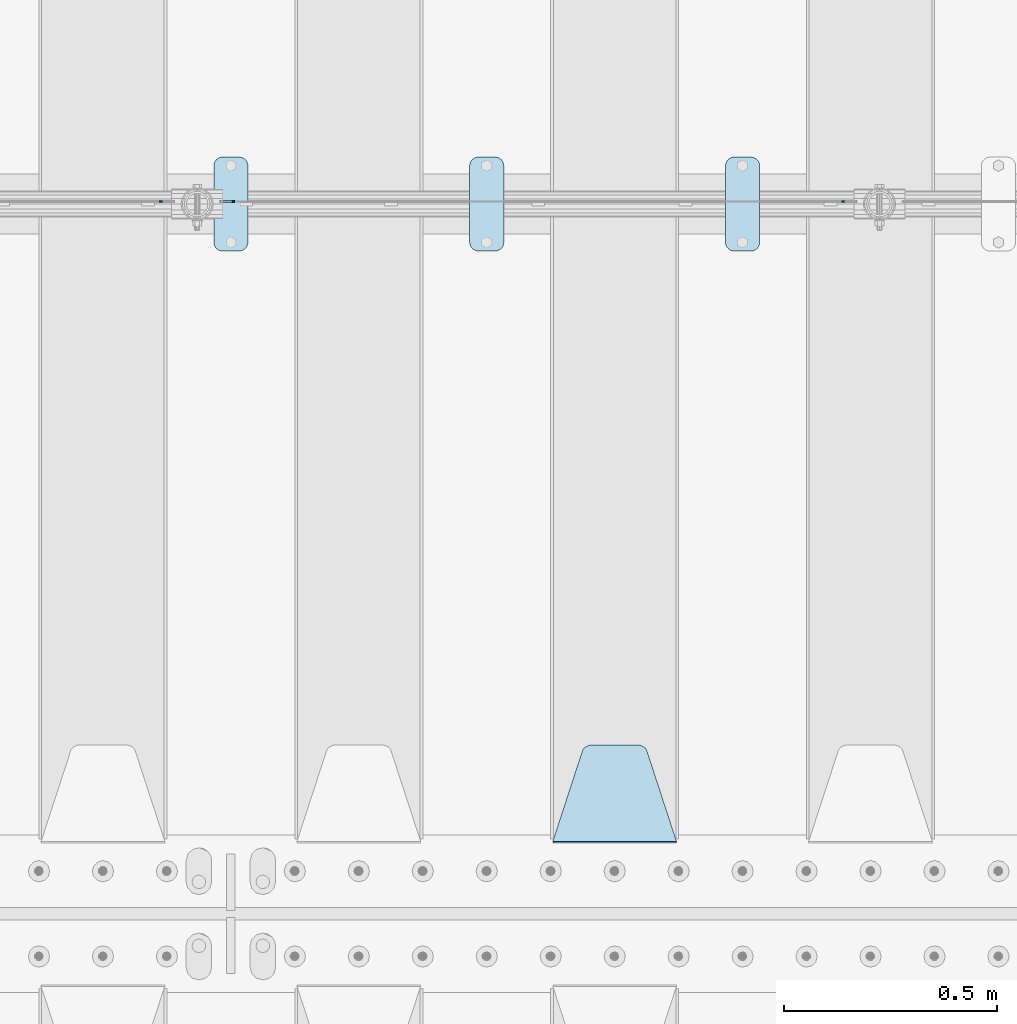
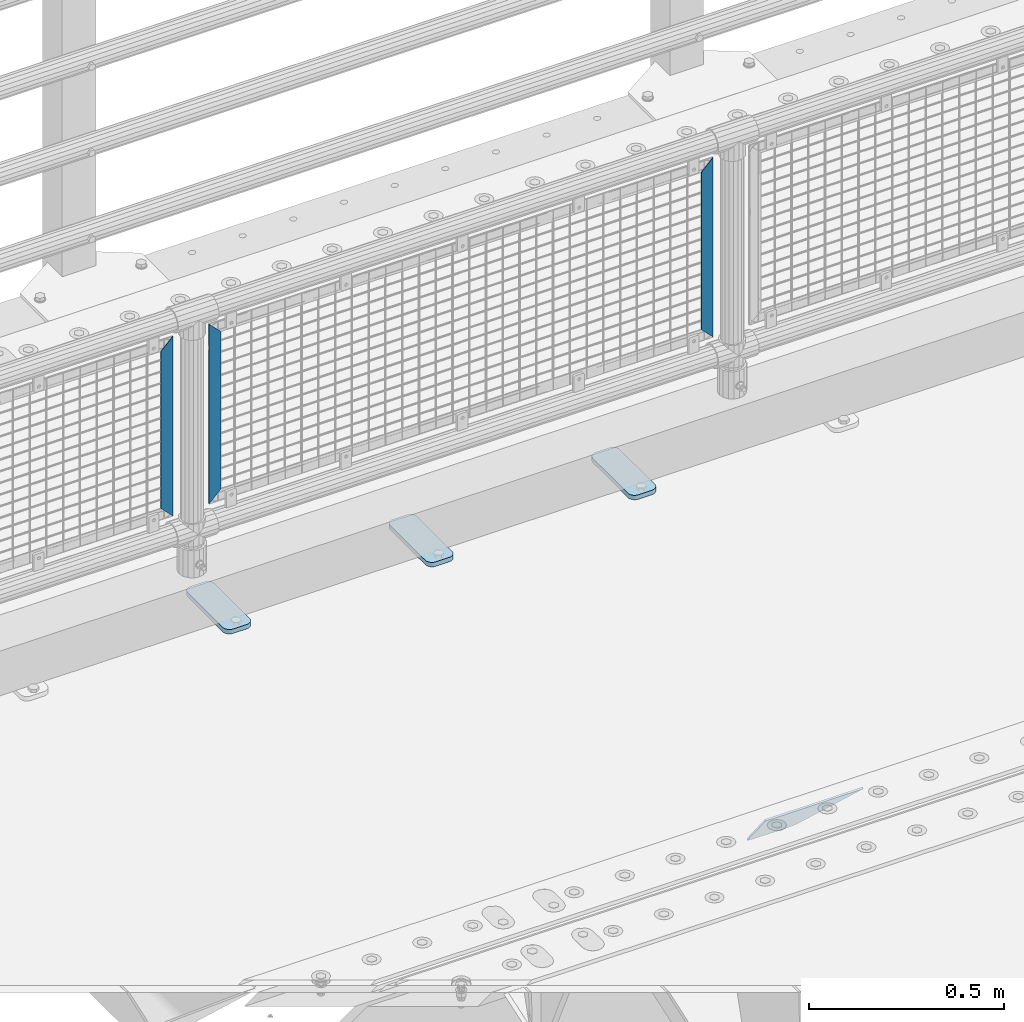
# One storey, part 221 of 257: 7 plates.
"""IFC2X3 building model written with IfcOpenShell, lengths in millimetres."""

from ifc_helpers import new_model, si_unit, frame, origin_with_axes, place, context, subcontext, project, spatial, faceted_brep, material, type_object, element, save


model = new_model("IFC2X3")

# Units and contexts
model_context = context("Model", 3, precision=1e-05, world=origin_with_axes())
body_context = subcontext(model_context, "Body", "Model", "MODEL_VIEW")
ifc_project = project(units=[si_unit("LENGTHUNIT", "METRE", prefix="MILLI"), si_unit("AREAUNIT", "SQUARE_METRE"), si_unit("VOLUMEUNIT", "CUBIC_METRE"), si_unit("MASSUNIT", "GRAM", prefix="KILO"), si_unit("TIMEUNIT", "SECOND"), si_unit("PLANEANGLEUNIT", "RADIAN"), si_unit("SOLIDANGLEUNIT", "STERADIAN"), si_unit("THERMODYNAMICTEMPERATUREUNIT", "DEGREE_CELSIUS"), si_unit("LUMINOUSINTENSITYUNIT", "LUMEN")], contexts=[model_context])

# Site, building, storey
site_placement = place(None, origin_with_axes())
site = spatial("IfcSite", under=ifc_project, at=site_placement, CompositionType="ELEMENT")
building_placement = place(site_placement, origin_with_axes())
building = spatial("IfcBuilding", under=site, at=building_placement, Name="Standard", CompositionType="ELEMENT")
storey_placement = place(building_placement, origin_with_axes())
storey = spatial("IfcBuildingStorey", under=building, at=storey_placement, Name="Undefined", CompositionType="ELEMENT", Elevation=0.0)

# Plates
ifc_material_1 = material(Name="STEEL/S355J2")
plate_type_1 = type_object("IfcPlateType", PredefinedType="NOTDEFINED")
plate_1_placement = place(storey_placement, frame((49110.0, 10774.5, 21.0199999999977), z_axis=(1.0, 0.0, 0.0), x_axis=(0.0, -1.0, 0.0)))
element("IfcPlate", 1, at=plate_1_placement, inside=storey, type_object=plate_type_1, material=ifc_material_1, context=body_context, shape_type="Brep", body=[
    faceted_brep([(0.0, -7.0, 20.0), (0.0, -7.0, 60.0), (0.0, 7.0, 60.0), (0.0, 7.0, 20.0), (0.384294391935327, -7.0, 63.9018064403208), (0.384294391935327, 7.0, 63.9018064403208), (1.52240934977453, -7.0, 67.6536686473046), (1.52240934977453, 7.0, 67.6536686473046), (3.37060775394821, -7.0, 71.1114046603907), (3.37060775394821, 7.0, 71.1114046603907), (5.85786437626848, -7.0, 74.1421356237333), (5.85786437626848, 7.0, 74.1421356237333), (8.88859533960749, -7.0, 76.6293922460536), (8.88859533960749, 7.0, 76.6293922460536), (12.3463313526991, -7.0, 78.4775906502255), (12.3463313526991, 7.0, 78.4775906502255), (16.0981935596774, -7.0, 79.6157056080629), (16.0981935596774, 7.0, 79.6157056080629), (20.0, -7.0, 80.0), (20.0, 7.0, 80.0), (200.0, -7.0, 80.0), (200.0, 7.0, 80.0), (203.901806440323, -7.0, 79.6157056080629), (203.901806440323, 7.0, 79.6157056080629), (207.653668647301, -7.0, 78.4775906502255), (207.653668647301, 7.0, 78.4775906502255), (211.111404660393, -7.0, 76.6293922460536), (211.111404660393, 7.0, 76.6293922460536), (214.142135623732, -7.0, 74.1421356237333), (214.142135623732, 7.0, 74.1421356237333), (216.629392246052, -7.0, 71.1114046603907), (216.629392246052, 7.0, 71.1114046603907), (218.477590650225, -7.0, 67.6536686473046), (218.477590650225, 7.0, 67.6536686473046), (219.615705608065, -7.0, 63.9018064403208), (219.615705608065, 7.0, 63.9018064403208), (220.0, -7.0, 60.0), (220.0, 7.0, 60.0), (220.0, -7.0, 20.0), (220.0, 7.0, 20.0), (219.615705608065, -7.0, 16.0981935596792), (219.615705608065, 7.0, 16.0981935596792), (218.477590650225, -7.0, 12.3463313526954), (218.477590650225, 7.0, 12.3463313526954), (216.629392246052, -7.0, 8.88859533960931), (216.629392246052, 7.0, 8.88859533960931), (214.142135623732, -7.0, 5.85786437626666), (214.142135623732, 7.0, 5.85786437626666), (211.111404660393, -7.0, 3.37060775394639), (211.111404660393, 7.0, 3.37060775394639), (207.653668647301, -7.0, 1.52240934977453), (207.653668647301, 7.0, 1.52240934977453), (203.901806440323, -7.0, 0.384294391937146), (203.901806440323, 7.0, 0.384294391937146), (200.0, -7.0, 0.0), (200.0, 7.0, 0.0), (20.0, -7.0, 0.0), (20.0, 7.0, 0.0), (16.0981935596774, -7.0, 0.384294391937146), (16.0981935596774, 7.0, 0.384294391937146), (12.3463313526991, -7.0, 1.52240934977453), (12.3463313526991, 7.0, 1.52240934977453), (8.88859533960749, -7.0, 3.37060775394639), (8.88859533960749, 7.0, 3.37060775394639), (5.85786437626848, -7.0, 5.85786437626666), (5.85786437626848, 7.0, 5.85786437626666), (3.37060775394821, -7.0, 8.88859533960931), (3.37060775394821, 7.0, 8.88859533960931), (1.52240934977453, -7.0, 12.3463313526954), (1.52240934977453, 7.0, 12.3463313526954), (0.384294391935327, -7.0, 16.0981935596792), (0.384294391935327, 7.0, 16.0981935596792)], [[[0, 1, 2, 3]], [[1, 4, 5, 2]], [[4, 6, 7, 5]], [[6, 8, 9, 7]], [[8, 10, 11, 9]], [[10, 12, 13, 11]], [[12, 14, 15, 13]], [[14, 16, 17, 15]], [[16, 18, 19, 17]], [[18, 20, 21, 19]], [[20, 22, 23, 21]], [[22, 24, 25, 23]], [[24, 26, 27, 25]], [[26, 28, 29, 27]], [[28, 30, 31, 29]], [[30, 32, 33, 31]], [[32, 34, 35, 33]], [[34, 36, 37, 35]], [[36, 38, 39, 37]], [[38, 40, 41, 39]], [[40, 42, 43, 41]], [[42, 44, 45, 43]], [[44, 46, 47, 45]], [[46, 48, 49, 47]], [[48, 50, 51, 49]], [[50, 52, 53, 51]], [[52, 54, 55, 53]], [[54, 56, 57, 55]], [[56, 58, 59, 57]], [[58, 60, 61, 59]], [[60, 62, 63, 61]], [[62, 64, 65, 63]], [[64, 66, 67, 65]], [[66, 68, 69, 67]], [[68, 70, 71, 69]], [[70, 0, 3, 71]], [[5, 7, 9, 11, 13, 15, 17, 19, 21, 23, 25, 27, 29, 31, 33, 35, 37, 39, 41, 43, 45, 47, 49, 51, 53, 55, 57, 59, 61, 63, 65, 67, 69, 71, 3, 2]], [[70, 68, 66, 64, 62, 60, 58, 56, 54, 52, 50, 48, 46, 44, 42, 40, 38, 36, 34, 32, 30, 28, 26, 24, 22, 20, 18, 16, 14, 12, 10, 8, 6, 4, 1, 0]]]),
])
plate_2_placement = place(storey_placement, frame((48510.0, 10774.5, 21.0199999999977), z_axis=(1.0, 0.0, 0.0), x_axis=(0.0, -1.0, 0.0)))
element("IfcPlate", 2, at=plate_2_placement, inside=storey, type_object=plate_type_1, material=ifc_material_1, context=body_context, shape_type="Brep", body=[
    faceted_brep([(0.0, -7.0, 20.0), (0.0, -7.0, 60.0), (0.0, 7.0, 60.0), (0.0, 7.0, 20.0), (0.384294391935327, -7.0, 63.9018064403208), (0.384294391935327, 7.0, 63.9018064403208), (1.52240934977453, -7.0, 67.6536686473046), (1.52240934977453, 7.0, 67.6536686473046), (3.37060775394821, -7.0, 71.1114046603907), (3.37060775394821, 7.0, 71.1114046603907), (5.85786437626848, -7.0, 74.1421356237333), (5.85786437626848, 7.0, 74.1421356237333), (8.88859533960749, -7.0, 76.6293922460536), (8.88859533960749, 7.0, 76.6293922460536), (12.3463313526991, -7.0, 78.4775906502255), (12.3463313526991, 7.0, 78.4775906502255), (16.0981935596774, -7.0, 79.6157056080629), (16.0981935596774, 7.0, 79.6157056080629), (20.0, -7.0, 80.0), (20.0, 7.0, 80.0), (200.0, -7.0, 80.0), (200.0, 7.0, 80.0), (203.901806440323, -7.0, 79.6157056080629), (203.901806440323, 7.0, 79.6157056080629), (207.653668647301, -7.0, 78.4775906502255), (207.653668647301, 7.0, 78.4775906502255), (211.111404660393, -7.0, 76.6293922460536), (211.111404660393, 7.0, 76.6293922460536), (214.142135623732, -7.0, 74.1421356237333), (214.142135623732, 7.0, 74.1421356237333), (216.629392246052, -7.0, 71.1114046603907), (216.629392246052, 7.0, 71.1114046603907), (218.477590650225, -7.0, 67.6536686473046), (218.477590650225, 7.0, 67.6536686473046), (219.615705608065, -7.0, 63.9018064403208), (219.615705608065, 7.0, 63.9018064403208), (220.0, -7.0, 60.0), (220.0, 7.0, 60.0), (220.0, -7.0, 20.0), (220.0, 7.0, 20.0), (219.615705608065, -7.0, 16.0981935596792), (219.615705608065, 7.0, 16.0981935596792), (218.477590650225, -7.0, 12.3463313526954), (218.477590650225, 7.0, 12.3463313526954), (216.629392246052, -7.0, 8.88859533960931), (216.629392246052, 7.0, 8.88859533960931), (214.142135623732, -7.0, 5.85786437626666), (214.142135623732, 7.0, 5.85786437626666), (211.111404660393, -7.0, 3.37060775394639), (211.111404660393, 7.0, 3.37060775394639), (207.653668647301, -7.0, 1.52240934977453), (207.653668647301, 7.0, 1.52240934977453), (203.901806440323, -7.0, 0.384294391937146), (203.901806440323, 7.0, 0.384294391937146), (200.0, -7.0, 0.0), (200.0, 7.0, 0.0), (20.0, -7.0, 0.0), (20.0, 7.0, 0.0), (16.0981935596774, -7.0, 0.384294391937146), (16.0981935596774, 7.0, 0.384294391937146), (12.3463313526991, -7.0, 1.52240934977453), (12.3463313526991, 7.0, 1.52240934977453), (8.88859533960749, -7.0, 3.37060775394639), (8.88859533960749, 7.0, 3.37060775394639), (5.85786437626848, -7.0, 5.85786437626666), (5.85786437626848, 7.0, 5.85786437626666), (3.37060775394821, -7.0, 8.88859533960931), (3.37060775394821, 7.0, 8.88859533960931), (1.52240934977453, -7.0, 12.3463313526954), (1.52240934977453, 7.0, 12.3463313526954), (0.384294391935327, -7.0, 16.0981935596792), (0.384294391935327, 7.0, 16.0981935596792)], [[[0, 1, 2, 3]], [[1, 4, 5, 2]], [[4, 6, 7, 5]], [[6, 8, 9, 7]], [[8, 10, 11, 9]], [[10, 12, 13, 11]], [[12, 14, 15, 13]], [[14, 16, 17, 15]], [[16, 18, 19, 17]], [[18, 20, 21, 19]], [[20, 22, 23, 21]], [[22, 24, 25, 23]], [[24, 26, 27, 25]], [[26, 28, 29, 27]], [[28, 30, 31, 29]], [[30, 32, 33, 31]], [[32, 34, 35, 33]], [[34, 36, 37, 35]], [[36, 38, 39, 37]], [[38, 40, 41, 39]], [[40, 42, 43, 41]], [[42, 44, 45, 43]], [[44, 46, 47, 45]], [[46, 48, 49, 47]], [[48, 50, 51, 49]], [[50, 52, 53, 51]], [[52, 54, 55, 53]], [[54, 56, 57, 55]], [[56, 58, 59, 57]], [[58, 60, 61, 59]], [[60, 62, 63, 61]], [[62, 64, 65, 63]], [[64, 66, 67, 65]], [[66, 68, 69, 67]], [[68, 70, 71, 69]], [[70, 0, 3, 71]], [[5, 7, 9, 11, 13, 15, 17, 19, 21, 23, 25, 27, 29, 31, 33, 35, 37, 39, 41, 43, 45, 47, 49, 51, 53, 55, 57, 59, 61, 63, 65, 67, 69, 71, 3, 2]], [[70, 68, 66, 64, 62, 60, 58, 56, 54, 52, 50, 48, 46, 44, 42, 40, 38, 36, 34, 32, 30, 28, 26, 24, 22, 20, 18, 16, 14, 12, 10, 8, 6, 4, 1, 0]]]),
])
plate_3_placement = place(storey_placement, frame((47910.0, 10774.5, 21.0199999999977), z_axis=(1.0, 0.0, 0.0), x_axis=(0.0, -1.0, 0.0)))
element("IfcPlate", 3, at=plate_3_placement, inside=storey, type_object=plate_type_1, material=ifc_material_1, context=body_context, shape_type="Brep", body=[
    faceted_brep([(0.0, -7.0, 20.0), (0.0, -7.0, 60.0), (0.0, 7.0, 60.0), (0.0, 7.0, 20.0), (0.384294391935327, -7.0, 63.9018064403208), (0.384294391935327, 7.0, 63.9018064403208), (1.52240934977453, -7.0, 67.6536686473046), (1.52240934977453, 7.0, 67.6536686473046), (3.37060775394821, -7.0, 71.1114046603907), (3.37060775394821, 7.0, 71.1114046603907), (5.85786437626848, -7.0, 74.1421356237333), (5.85786437626848, 7.0, 74.1421356237333), (8.88859533960749, -7.0, 76.6293922460536), (8.88859533960749, 7.0, 76.6293922460536), (12.3463313526991, -7.0, 78.4775906502255), (12.3463313526991, 7.0, 78.4775906502255), (16.0981935596774, -7.0, 79.6157056080629), (16.0981935596774, 7.0, 79.6157056080629), (20.0, -7.0, 80.0), (20.0, 7.0, 80.0), (200.0, -7.0, 80.0), (200.0, 7.0, 80.0), (203.901806440323, -7.0, 79.6157056080629), (203.901806440323, 7.0, 79.6157056080629), (207.653668647301, -7.0, 78.4775906502255), (207.653668647301, 7.0, 78.4775906502255), (211.111404660393, -7.0, 76.6293922460536), (211.111404660393, 7.0, 76.6293922460536), (214.142135623732, -7.0, 74.1421356237333), (214.142135623732, 7.0, 74.1421356237333), (216.629392246052, -7.0, 71.1114046603907), (216.629392246052, 7.0, 71.1114046603907), (218.477590650225, -7.0, 67.6536686473046), (218.477590650225, 7.0, 67.6536686473046), (219.615705608065, -7.0, 63.9018064403208), (219.615705608065, 7.0, 63.9018064403208), (220.0, -7.0, 60.0), (220.0, 7.0, 60.0), (220.0, -7.0, 20.0), (220.0, 7.0, 20.0), (219.615705608065, -7.0, 16.0981935596792), (219.615705608065, 7.0, 16.0981935596792), (218.477590650225, -7.0, 12.3463313526954), (218.477590650225, 7.0, 12.3463313526954), (216.629392246052, -7.0, 8.88859533960931), (216.629392246052, 7.0, 8.88859533960931), (214.142135623732, -7.0, 5.85786437626666), (214.142135623732, 7.0, 5.85786437626666), (211.111404660393, -7.0, 3.37060775394639), (211.111404660393, 7.0, 3.37060775394639), (207.653668647301, -7.0, 1.52240934977453), (207.653668647301, 7.0, 1.52240934977453), (203.901806440323, -7.0, 0.384294391937146), (203.901806440323, 7.0, 0.384294391937146), (200.0, -7.0, 0.0), (200.0, 7.0, 0.0), (20.0, -7.0, 0.0), (20.0, 7.0, 0.0), (16.0981935596774, -7.0, 0.384294391937146), (16.0981935596774, 7.0, 0.384294391937146), (12.3463313526991, -7.0, 1.52240934977453), (12.3463313526991, 7.0, 1.52240934977453), (8.88859533960749, -7.0, 3.37060775394639), (8.88859533960749, 7.0, 3.37060775394639), (5.85786437626848, -7.0, 5.85786437626666), (5.85786437626848, 7.0, 5.85786437626666), (3.37060775394821, -7.0, 8.88859533960931), (3.37060775394821, 7.0, 8.88859533960931), (1.52240934977453, -7.0, 12.3463313526954), (1.52240934977453, 7.0, 12.3463313526954), (0.384294391935327, -7.0, 16.0981935596792), (0.384294391935327, 7.0, 16.0981935596792)], [[[0, 1, 2, 3]], [[1, 4, 5, 2]], [[4, 6, 7, 5]], [[6, 8, 9, 7]], [[8, 10, 11, 9]], [[10, 12, 13, 11]], [[12, 14, 15, 13]], [[14, 16, 17, 15]], [[16, 18, 19, 17]], [[18, 20, 21, 19]], [[20, 22, 23, 21]], [[22, 24, 25, 23]], [[24, 26, 27, 25]], [[26, 28, 29, 27]], [[28, 30, 31, 29]], [[30, 32, 33, 31]], [[32, 34, 35, 33]], [[34, 36, 37, 35]], [[36, 38, 39, 37]], [[38, 40, 41, 39]], [[40, 42, 43, 41]], [[42, 44, 45, 43]], [[44, 46, 47, 45]], [[46, 48, 49, 47]], [[48, 50, 51, 49]], [[50, 52, 53, 51]], [[52, 54, 55, 53]], [[54, 56, 57, 55]], [[56, 58, 59, 57]], [[58, 60, 61, 59]], [[60, 62, 63, 61]], [[62, 64, 65, 63]], [[64, 66, 67, 65]], [[66, 68, 69, 67]], [[68, 70, 71, 69]], [[70, 0, 3, 71]], [[5, 7, 9, 11, 13, 15, 17, 19, 21, 23, 25, 27, 29, 31, 33, 35, 37, 39, 41, 43, 45, 47, 49, 51, 53, 55, 57, 59, 61, 63, 65, 67, 69, 71, 3, 2]], [[70, 68, 66, 64, 62, 60, 58, 56, 54, 52, 50, 48, 46, 44, 42, 40, 38, 36, 34, 32, 30, 28, 26, 24, 22, 20, 18, 16, 14, 12, 10, 8, 6, 4, 1, 0]]]),
])
ifc_material_2 = material(Name="STEEL/S355N")
plate_type_2 = type_object("IfcPlateType", PredefinedType="NOTDEFINED")
plate_4_placement = place(storey_placement, frame((48995.0, 9168.23223304703, -1.76776695296758), z_axis=(0.0, 0.707106781186547, -0.707106781186548), x_axis=(-1.0, 0.0, 0.0)))
element("IfcPlate", 4, at=plate_4_placement, inside=storey, type_object=plate_type_2, material=ifc_material_2, context=body_context, shape_type="Brep", body=[
    faceted_brep([(0.0, -2.5, 0.0), (69.345504679477, -2.50000000000091, 300.17173142483), (69.345504679477, 2.5, 300.171731424831), (0.0, 2.5, 0.0), (70.927406119954, -2.50000000000091, 304.8974424154), (70.927406119954, 2.5, 304.8974424154), (73.3818627772271, -2.50000000000091, 309.234538108527), (73.3818627772271, 2.49999999999909, 309.234538108527), (76.6187032999587, -2.5, 313.023683126103), (76.6187032999587, 2.5, 313.023683126103), (80.5190132705029, -2.5, 316.125672595372), (80.5190132705029, 2.5, 316.125672595371), (84.9395038596849, -2.5, 318.426546230476), (84.9395038596849, 2.5, 318.426546230477), (89.7177759439219, -2.5, 319.841774983275), (89.7177759439219, 2.5, 319.841774983275), (94.6782862926484, -2.5, 320.319366455079), (94.6782862926484, 2.5, 320.319366455079), (195.321713707352, -2.5, 320.319366455079), (195.321713707352, 2.5, 320.319366455079), (200.282224056078, -2.5, 319.841774983275), (200.282224056078, 2.49999999999909, 319.841774983275), (205.060496140315, -2.5, 318.426546230476), (205.060496140315, 2.49999999999909, 318.426546230475), (209.480986729497, -2.5, 316.125672595371), (209.480986729497, 2.5, 316.125672595371), (213.381296700041, -2.50000000000091, 313.023683126102), (213.381296700041, 2.5, 313.023683126103), (216.618137222766, -2.50000000000091, 309.234538108527), (216.618137222766, 2.5, 309.234538108527), (219.072593880039, -2.5, 304.897442415399), (219.072593880039, 2.5, 304.897442415399), (220.654495320523, -2.50000000000091, 300.17173142483), (220.654495320523, 2.5, 300.171731424831), (290.0, -2.50000000000091, 0.0), (290.0, 2.5, 9.09494701772928e-13)], [[[0, 1, 2, 3]], [[1, 4, 5, 2]], [[4, 6, 7, 5]], [[6, 8, 9, 7]], [[8, 10, 11, 9]], [[10, 12, 13, 11]], [[12, 14, 15, 13]], [[14, 16, 17, 15]], [[16, 18, 19, 17]], [[18, 20, 21, 19]], [[20, 22, 23, 21]], [[22, 24, 25, 23]], [[24, 26, 27, 25]], [[26, 28, 29, 27]], [[28, 30, 31, 29]], [[30, 32, 33, 31]], [[32, 34, 35, 33]], [[34, 0, 3, 35]], [[5, 7, 9, 11, 13, 15, 17, 19, 21, 23, 25, 27, 29, 31, 33, 35, 3, 2]], [[34, 32, 30, 28, 26, 24, 22, 20, 18, 16, 14, 12, 10, 8, 6, 4, 1, 0]]]),
])
ifc_material_3 = material(Name="Misc_Undefined")
plate_type_3 = type_object("IfcPlateType", PredefinedType="NOTDEFINED")
plate_5_placement = place(storey_placement, frame((47959.509713541, 10670.5, 879.519963133601), z_axis=(-0.707008801899317, 0.0, -0.707204746899292), x_axis=(-0.707204746899293, 0.0, 0.707008801899317)))
element("IfcPlate", 5, at=plate_5_placement, inside=storey, type_object=plate_type_3, material=ifc_material_3, context=body_context, shape_type="Brep", body=[
    faceted_brep([(0.0, -1.5, -5.6843418860808e-14), (-348.552185058586, -1.5, 348.655029296868), (-348.552185058586, 1.5, 348.655029296868), (0.0, 1.5, -5.6843418860808e-14), (-348.544891357407, -1.5, 398.152496337891), (-348.544891357407, 1.5, 398.152496337891), (49.5043945312573, -1.5, 7.27595761418343e-11), (49.5043945312573, 1.5, 7.27595761418343e-11)], [[[0, 1, 2, 3]], [[1, 4, 5, 2]], [[4, 6, 7, 5]], [[6, 0, 3, 7]], [[5, 7, 3, 2]], [[6, 4, 1, 0]]]),
])
for number, where, z_axis, x_axis in (
    (6, (49382.4996874836, 10670.5, 879.52), (0.707103624179501, 0.0, -0.707109938179499), (0.707109938179525, 0.0, 0.707103624179475)),
    (7, (47782.4996874836, 10670.5, 879.52), (0.707103624179501, 0.0, -0.707109938179499), (0.707109938179525, 0.0, 0.707103624179475)),
):
    element("IfcPlate", number, at=place(storey_placement, frame(where, z_axis=z_axis, x_axis=x_axis)), inside=storey, type_object=plate_type_3, material=ifc_material_3, context=body_context, shape_type="Brep", body=[
        faceted_brep([(0.0, -1.5, -5.6843418860808e-14), (-348.605163574226, -1.5, 348.602081298828), (-348.605163574226, 1.5, 348.602081298828), (0.0, 1.5, -5.6843418860808e-14), (-348.605163574226, -1.5, 398.099334716804), (-348.605163574226, 1.5, 398.099334716804), (49.4976959228443, -1.5, 6.54836185276508e-11), (49.4976959228443, 1.5, 6.54836185276508e-11)], [[[0, 1, 2, 3]], [[1, 4, 5, 2]], [[4, 6, 7, 5]], [[6, 0, 3, 7]], [[5, 7, 3, 2]], [[6, 4, 1, 0]]]),
    ])

save(model, "model.ifc")
